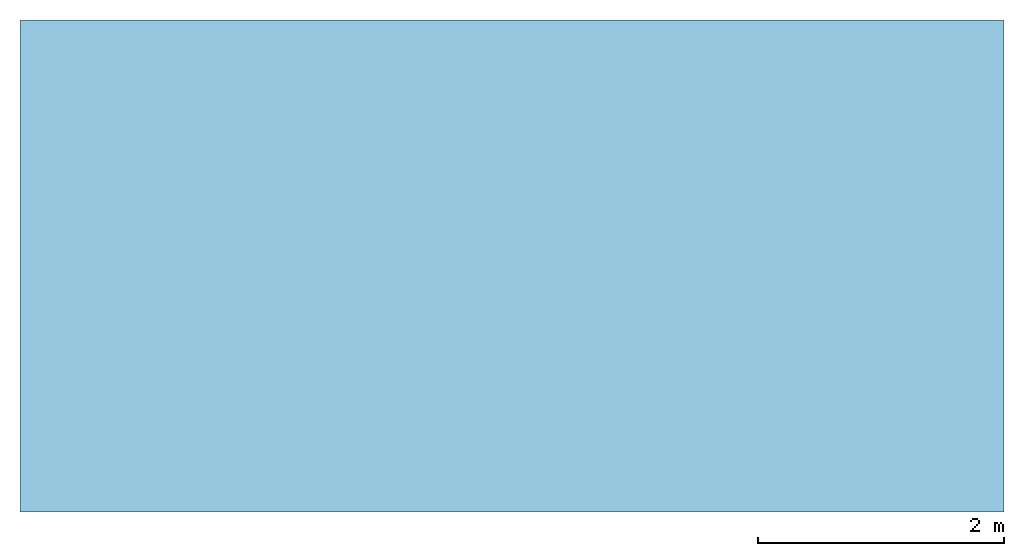
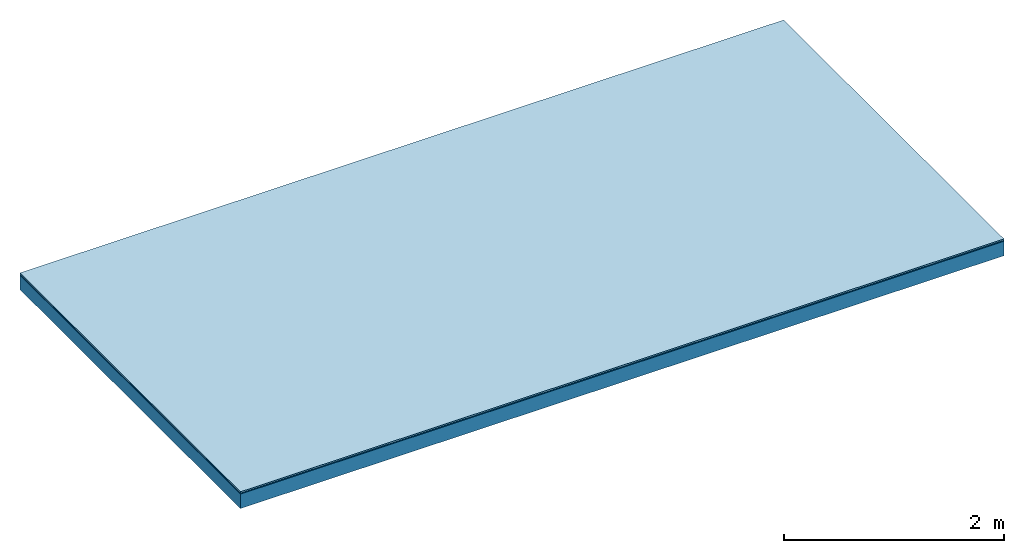
# One storey: 3 plates, 1 member, 1 element without a shape of its own.
"""IFC4 building model written with IfcOpenShell, lengths in metres."""

from ifc_helpers import new_model, si_unit, derived_unit, direction, frame, frame_2d, origin, origin_with_axes, place, context, project, spatial, rectangle, extrude, material, layer, layer_set, type_object, element, aggregate, save


model = new_model("IFC4")

# Units and contexts
plan_context = context("Plan", 3, precision=1e-05, world=origin(), true_north=direction((0.0, 1.0)))
model_context = context("Model", 3, precision=1e-05, world=origin(), true_north=direction((0.0, 1.0)))
ifc_project = project(units=[si_unit("LENGTHUNIT", "METRE"), derived_unit("SOUNDPRESSUREUNIT", [(si_unit("PRESSUREUNIT", "PASCAL", prefix="MICRO"), 0)]), si_unit("ENERGYUNIT", "JOULE", prefix="MEGA"), si_unit("MASSUNIT", "GRAM", prefix="KILO"), derived_unit("THERMALTRANSMITTANCEUNIT", [(si_unit("POWERUNIT", "WATT"), 1), (si_unit("AREAUNIT", "SQUARE_METRE"), -1), (si_unit("THERMODYNAMICTEMPERATUREUNIT", "KELVIN"), -1)]), derived_unit("AREADENSITYUNIT", [(si_unit("MASSUNIT", "GRAM", prefix="KILO"), 1), (si_unit("AREAUNIT", "SQUARE_METRE"), -1)]), derived_unit("USERDEFINED", [(si_unit("ENERGYUNIT", "JOULE", prefix="MEGA"), 1), (si_unit("AREAUNIT", "SQUARE_METRE"), -1)])], contexts=[plan_context, model_context])

# Site, building, storey
site = spatial("IfcSite", under=ifc_project)
building_placement = place(None, origin())
building = spatial("IfcBuilding", under=site, at=building_placement)
storey_placement = place(building_placement, origin())
storey = spatial("IfcBuildingStorey", under=building, at=storey_placement)

# Slab, member, plates
ifc_material_1 = material(Category="11.013")
ifc_layer_1 = layer(ifc_material_1, 0.015, Name="Flooring")
ifc_material_2 = material(Name="Wood fiber generic product", Category="10.009")
ifc_layer_2 = layer(ifc_material_2, 0.01, Name="Impact sound insulation")
ifc_material_3 = material(Name="protection", Category="09.007")
ifc_layer_3 = layer(ifc_material_3, 0.0005, Name="Sub-floor")
ifc_material_4 = material(Name="no composite action")
ifc_layer_4 = layer(ifc_material_4, 0.0, Name="Bond")
ifc_layer_5 = layer(None, 0.16, Name="Supporting structure")
ifc_layer_set = layer_set([ifc_layer_1, ifc_layer_2, ifc_layer_3, ifc_layer_4, ifc_layer_5])
slab_type = type_object("IfcSlabType", Name="A2008", PredefinedType="NOTDEFINED", material=ifc_layer_set)
slab_placement = place(None, frame((0.0, 0.0, 0.0), z_axis=(0.0, 0.0, -1.0), x_axis=(1.0, 0.0, 0.0)))
slab = element("IfcSlab", 1, at=slab_placement, inside=storey, type_object=slab_type, material=ifc_layer_set, Name="Slab #1")
ifc_material_5 = material(Name="Solid timber panel")
member_placement = place(slab_placement, origin())
member = element("IfcMember", 2, at=member_placement, material=ifc_material_5, Name="Supporting structure", context=plan_context, shape_type="SweptSolid", body=[
    extrude(rectangle(XDim=1.0, YDim=0.16, at=frame_2d((0.5, 0.08), x_axis=(1.0, 0.0))), frame((0.0, 4.0, 0.0255), z_axis=(0.0, -1.0, 0.0), x_axis=(1.0, 0.0, 0.0)), (0.0, 0.0, 1.0), 4.0),
    extrude(rectangle(XDim=1.0, YDim=0.16, at=frame_2d((0.5, 0.08), x_axis=(1.0, 0.0))), frame((1.0, 4.0, 0.0255), z_axis=(0.0, -1.0, 0.0), x_axis=(1.0, 0.0, 0.0)), (0.0, 0.0, 1.0), 4.0),
    extrude(rectangle(XDim=1.0, YDim=0.16, at=frame_2d((0.5, 0.08), x_axis=(1.0, 0.0))), frame((2.0, 4.0, 0.0255), z_axis=(0.0, -1.0, 0.0), x_axis=(1.0, 0.0, 0.0)), (0.0, 0.0, 1.0), 4.0),
    extrude(rectangle(XDim=1.0, YDim=0.16, at=frame_2d((0.5, 0.08), x_axis=(1.0, 0.0))), frame((3.0, 4.0, 0.0255), z_axis=(0.0, -1.0, 0.0), x_axis=(1.0, 0.0, 0.0)), (0.0, 0.0, 1.0), 4.0),
    extrude(rectangle(XDim=1.0, YDim=0.16, at=frame_2d((0.5, 0.08), x_axis=(1.0, 0.0))), frame((4.0, 4.0, 0.0255), z_axis=(0.0, -1.0, 0.0), x_axis=(1.0, 0.0, 0.0)), (0.0, 0.0, 1.0), 4.0),
    extrude(rectangle(XDim=1.0, YDim=0.16, at=frame_2d((0.5, 0.08), x_axis=(1.0, 0.0))), frame((5.0, 4.0, 0.0255), z_axis=(0.0, -1.0, 0.0), x_axis=(1.0, 0.0, 0.0)), (0.0, 0.0, 1.0), 4.0),
    extrude(rectangle(XDim=1.0, YDim=0.16, at=frame_2d((0.5, 0.08), x_axis=(1.0, 0.0))), frame((6.0, 4.0, 0.0255), z_axis=(0.0, -1.0, 0.0), x_axis=(1.0, 0.0, 0.0)), (0.0, 0.0, 1.0), 4.0),
    extrude(rectangle(XDim=1.0, YDim=0.16, at=frame_2d((0.5, 0.08), x_axis=(1.0, 0.0))), frame((7.0, 4.0, 0.0255), z_axis=(0.0, -1.0, 0.0), x_axis=(1.0, 0.0, 0.0)), (0.0, 0.0, 1.0), 4.0),
])
plate_1_placement = place(slab_placement, origin())
plate_1 = element("IfcPlate", 3, at=plate_1_placement, material=ifc_material_1, Name="Flooring", context=plan_context, shape_type="SweptSolid", body=[
    extrude(rectangle(XDim=8.0, YDim=4.0, at=frame_2d((4.0, 2.0), x_axis=(1.0, 0.0))), origin_with_axes(), (0.0, 0.0, 1.0), 0.015),
])
plate_2_placement = place(slab_placement, origin())
plate_2 = element("IfcPlate", 4, at=plate_2_placement, material=ifc_material_2, Name="Impact sound insulation", context=plan_context, shape_type="SweptSolid", body=[
    extrude(rectangle(XDim=8.0, YDim=4.0, at=frame_2d((4.0, 2.0), x_axis=(1.0, 0.0))), frame((0.0, 0.0, 0.015), z_axis=(0.0, 0.0, 1.0), x_axis=(1.0, 0.0, 0.0)), (0.0, 0.0, 1.0), 0.01),
])
plate_3_placement = place(slab_placement, origin())
plate_3 = element("IfcPlate", 5, at=plate_3_placement, material=ifc_material_3, Name="Sub-floor", context=plan_context, shape_type="SweptSolid", body=[
    extrude(rectangle(XDim=8.0, YDim=4.0, at=frame_2d((4.0, 2.0), x_axis=(1.0, 0.0))), frame((0.0, 0.0, 0.025), z_axis=(0.0, 0.0, 1.0), x_axis=(1.0, 0.0, 0.0)), (0.0, 0.0, 1.0), 0.0005),
])
aggregate(slab, [plate_1, plate_2, plate_3, member])

save(model, "model.ifc")
